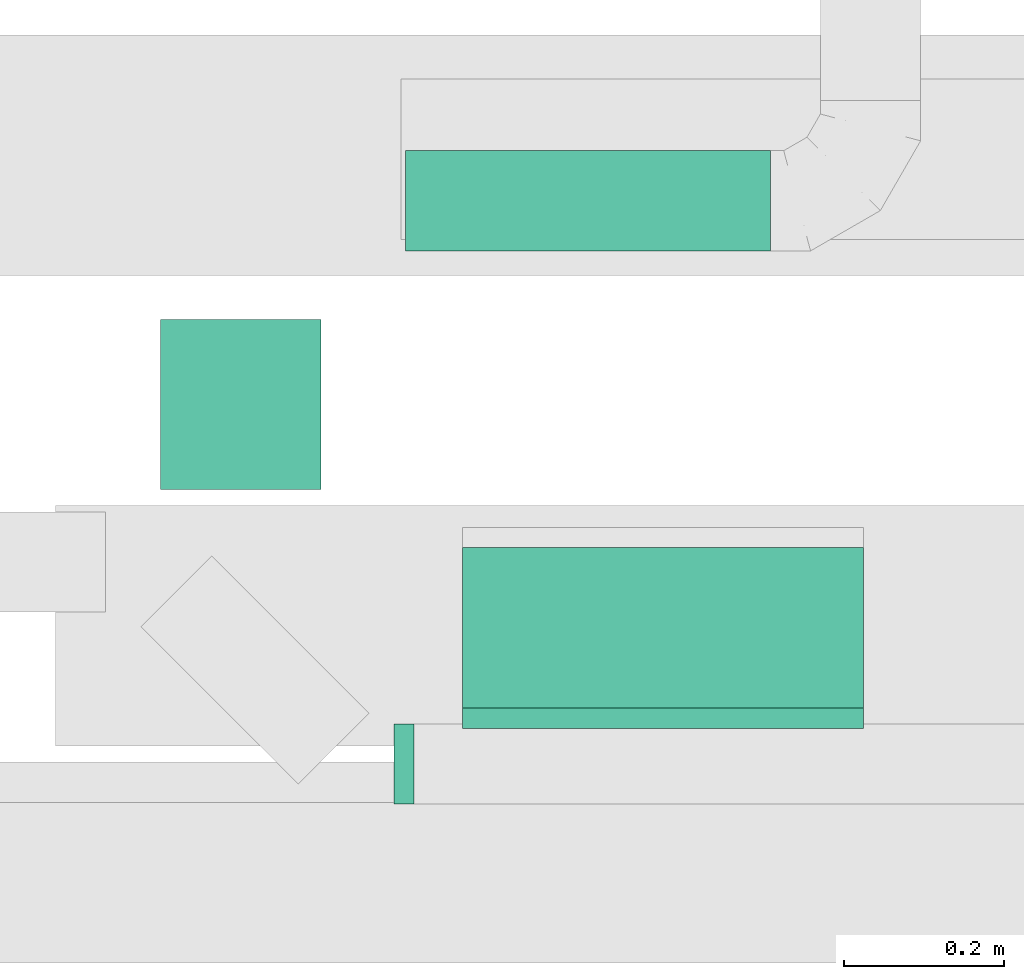
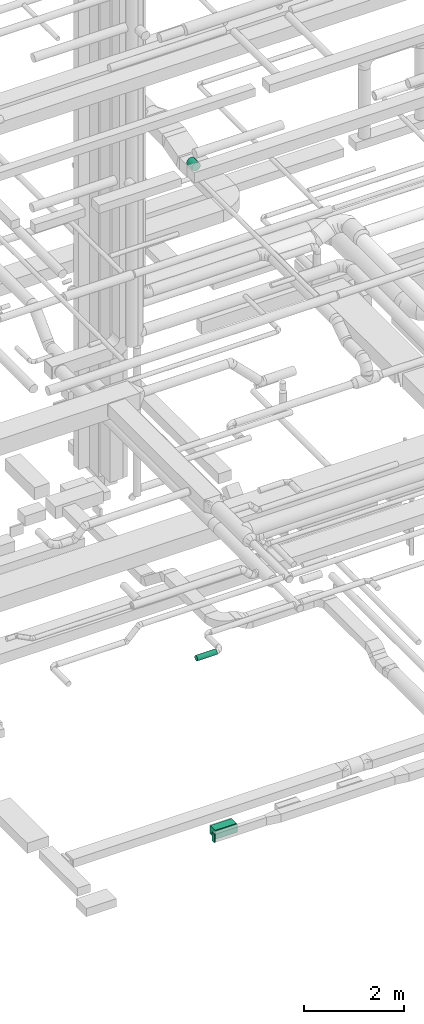
# One storey, part 115 of 337: 3 flow segments, 2 flow fittings.
"""IFC2X3 building model written with IfcOpenShell, lengths in millimetres."""

from ifc_helpers import new_model, entity, si_unit, converted_unit, derived_unit, direction, frame, origin, origin_2d_with_axis, place, context, subcontext, project, spatial, rectangle, circle, extrude, source, transform, mapped, material, type_object, type_shapes, element, save


model = new_model("IFC2X3")

# Units and contexts
model_context = context("Model", 3, precision=0.01, world=origin(), true_north=direction((6.12303176911189e-17, 1.0)))
body_context = subcontext(model_context, "Body", "Model", "MODEL_VIEW")
ifc_project = project(units=[si_unit("LENGTHUNIT", "METRE", prefix="MILLI"), si_unit("AREAUNIT", "SQUARE_METRE"), si_unit("VOLUMEUNIT", "CUBIC_METRE"), converted_unit("PLANEANGLEUNIT", "DEGREE", entity("IfcRatioMeasure", 0.0174532925199433), si_unit("PLANEANGLEUNIT", "RADIAN"), dimensions=[0, 0, 0, 0, 0, 0, 0]), si_unit("MASSUNIT", "GRAM", prefix="KILO"), derived_unit("MASSDENSITYUNIT", [(si_unit("MASSUNIT", "GRAM", prefix="KILO"), 1), (si_unit("LENGTHUNIT", "METRE"), -3)]), derived_unit("MOMENTOFINERTIAUNIT", [(si_unit("LENGTHUNIT", "METRE"), 4)]), si_unit("TIMEUNIT", "SECOND"), si_unit("FREQUENCYUNIT", "HERTZ"), si_unit("THERMODYNAMICTEMPERATUREUNIT", "DEGREE_CELSIUS"), derived_unit("THERMALTRANSMITTANCEUNIT", [(si_unit("MASSUNIT", "GRAM", prefix="KILO"), 1), (si_unit("THERMODYNAMICTEMPERATUREUNIT", "KELVIN"), -1), (si_unit("TIMEUNIT", "SECOND"), -3)]), derived_unit("VOLUMETRICFLOWRATEUNIT", [(si_unit("LENGTHUNIT", "METRE"), 3), (si_unit("TIMEUNIT", "SECOND"), -1)]), derived_unit("MASSFLOWRATEUNIT", [(si_unit("MASSUNIT", "GRAM", prefix="KILO"), 1), (si_unit("TIMEUNIT", "SECOND"), -1)]), derived_unit("ROTATIONALFREQUENCYUNIT", [(si_unit("TIMEUNIT", "SECOND"), -1)]), si_unit("ELECTRICCURRENTUNIT", "AMPERE"), si_unit("ELECTRICVOLTAGEUNIT", "VOLT"), si_unit("POWERUNIT", "WATT"), si_unit("FORCEUNIT", "NEWTON", prefix="KILO"), si_unit("ILLUMINANCEUNIT", "LUX"), si_unit("LUMINOUSFLUXUNIT", "LUMEN"), si_unit("LUMINOUSINTENSITYUNIT", "CANDELA"), derived_unit("USERDEFINED", [(si_unit("MASSUNIT", "GRAM", prefix="KILO"), -1), (si_unit("LENGTHUNIT", "METRE"), -2), (si_unit("TIMEUNIT", "SECOND"), 3), (si_unit("LUMINOUSFLUXUNIT", "LUMEN"), 1)]), derived_unit("LINEARVELOCITYUNIT", [(si_unit("LENGTHUNIT", "METRE"), 1), (si_unit("TIMEUNIT", "SECOND"), -1)]), si_unit("PRESSUREUNIT", "PASCAL"), derived_unit("USERDEFINED", [(si_unit("LENGTHUNIT", "METRE"), -2), (si_unit("MASSUNIT", "GRAM", prefix="KILO"), 1), (si_unit("TIMEUNIT", "SECOND"), -2)]), derived_unit("LINEARFORCEUNIT", [(si_unit("MASSUNIT", "GRAM", prefix="KILO"), 1), (si_unit("LENGTHUNIT", "METRE"), 1), (si_unit("TIMEUNIT", "SECOND"), -2), (si_unit("LENGTHUNIT", "METRE"), -1)]), derived_unit("PLANARFORCEUNIT", [(si_unit("MASSUNIT", "GRAM", prefix="KILO"), 1), (si_unit("LENGTHUNIT", "METRE"), 1), (si_unit("TIMEUNIT", "SECOND"), -2), (si_unit("LENGTHUNIT", "METRE"), -2)])], contexts=[model_context])

# Site, building, storey
site_placement = place(None, origin())
site = spatial("IfcSite", under=ifc_project, at=site_placement, CompositionType="ELEMENT")
building_placement = place(site_placement, origin())
building = spatial("IfcBuilding", under=site, at=building_placement, CompositionType="ELEMENT")
storey_placement = place(building_placement, origin())
storey = spatial("IfcBuildingStorey", under=building, at=storey_placement, CompositionType="ELEMENT", Elevation=0.0)

# Flow segments
duct_segment_type_1 = type_object("IfcDuctSegmentType", PredefinedType="NOTDEFINED")
flow_segment_1_placement = place(storey_placement, frame((26990.21, 718.22, -1000.0)))
element("IfcFlowSegment", 1, at=flow_segment_1_placement, inside=storey, type_object=duct_segment_type_1, context=body_context, shape_type="SweptSolid", body=[
    extrude(rectangle(XDim=200.0, YDim=499.999999999999, at=origin_2d_with_axis()), frame((250.0, 100.0, 0.0), z_axis=(0.0, 0.0, 1.0), x_axis=(0.0, 1.0, 0.0)), (0.0, 0.0, 1.0), 200.0),
])
duct_segment_type_2 = type_object("IfcDuctSegmentType", PredefinedType="NOTDEFINED")
flow_segment_2_placement = place(storey_placement, frame((26611.86, 990.66, 15248.4)))
element("IfcFlowSegment", 2, at=flow_segment_2_placement, inside=storey, type_object=duct_segment_type_2, context=body_context, shape_type="SweptSolid", body=[
    extrude(circle(Radius=100.0, at=origin_2d_with_axis()), frame((101.6, 0.0, 101.6), z_axis=(0.0, 1.0, 0.0), x_axis=(1.0, 0.0, 0.0)), (0.0, 0.0, 1.0), 211.742634044902),
])
flow_segment_3_placement = place(storey_placement, frame((26919.02, 1286.61, 2985.9)))
element("IfcFlowSegment", 3, at=flow_segment_3_placement, inside=storey, type_object=duct_segment_type_2, context=body_context, shape_type="SweptSolid", body=[
    extrude(circle(Radius=62.5, at=origin_2d_with_axis()), frame((0.0, 64.1, 64.1), z_axis=(1.0, 0.0, 0.0), x_axis=(0.0, 1.0, 0.0)), (0.0, 0.0, 1.0), 455.000000000005),
])

# Flow fittings
ifc_material = material()
duct_fitting_type_1 = type_object("IfcDuctFittingType", PredefinedType="NOTDEFINED", material=ifc_material)
shared_shape_1 = source(origin(), body_context, "Body", "SweptSolid", [
    extrude(rectangle(XDim=26.0960000000008, YDim=500.0, at=origin_2d_with_axis()), frame((6.95, 0.0, -100.0)), (0.0, 0.0, 1.0), 200.0),
])
type_shapes(duct_fitting_type_1, [shared_shape_1])
flow_fitting_1_placement = place(storey_placement, frame((27240.21, 698.22, -900.0), z_axis=(0.0, 0.0, -1.0), x_axis=(0.0, 1.0, 0.0)))
element("IfcFlowFitting", 4, at=flow_fitting_1_placement, inside=storey, type_object=duct_fitting_type_1, material=ifc_material, context=body_context, shape_type="MappedRepresentation", body=[
    mapped(shared_shape_1, transform((0.0, 0.0, 0.0), scale=1.0)),
])
duct_fitting_type_2 = type_object("IfcDuctFittingType", PredefinedType="NOTDEFINED", material=ifc_material)
shared_shape_2 = source(origin(), body_context, "Body", "SweptSolid", [
    extrude(rectangle(XDim=24.9999999999999, YDim=100.0, at=origin_2d_with_axis()), frame((12.5, 0.0, -100.0)), (0.0, 0.0, 1.0), 200.0),
])
type_shapes(duct_fitting_type_2, [shared_shape_2])
flow_fitting_2_placement = place(storey_placement, frame((26929.6, 648.22, -900.0), z_axis=(0.0, 0.0, 1.0), x_axis=(-1.0, 0.0, 0.0)))
element("IfcFlowFitting", 5, at=flow_fitting_2_placement, inside=storey, type_object=duct_fitting_type_2, material=ifc_material, context=body_context, shape_type="MappedRepresentation", body=[
    mapped(shared_shape_2, transform((0.0, 0.0, 0.0), scale=1.0)),
])

save(model, "model.ifc")
